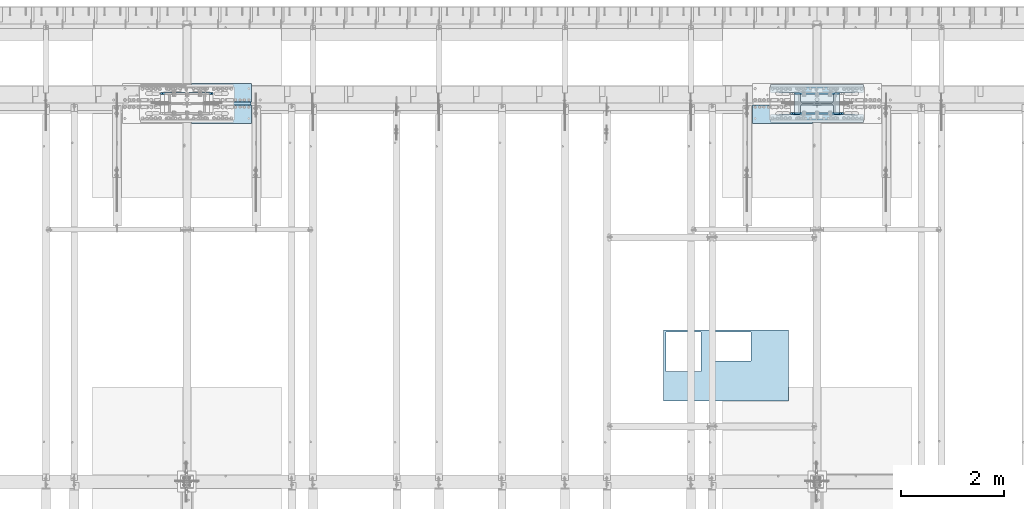
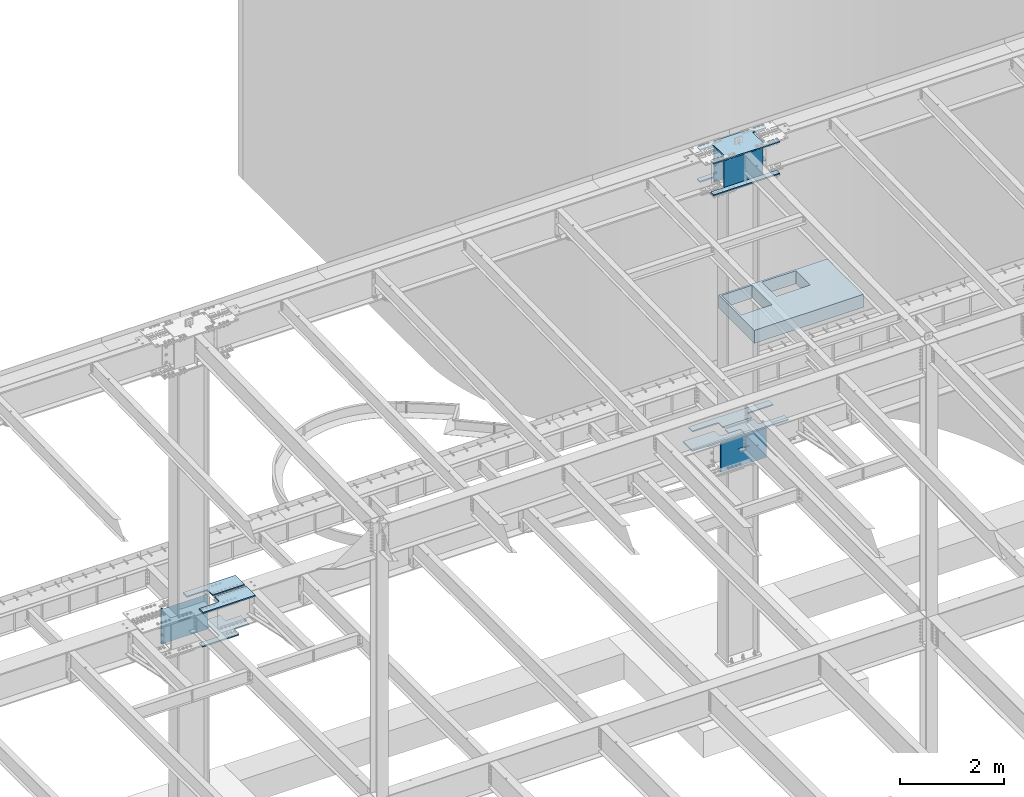
# One storey, part 1422 of 1763: 14 plates, 7 elements without a shape of their own.
"""IFC2X3 building model written with IfcOpenShell, lengths in millimetres."""

from ifc_helpers import new_model, si_unit, frame, origin_with_axes, place, context, subcontext, project, spatial, faceted_brep, material, type_object, element, aggregate, save


model = new_model("IFC2X3")

# Units and contexts
model_context = context("Model", 3, precision=1e-05, world=origin_with_axes())
body_context = subcontext(model_context, "Body", "Model", "MODEL_VIEW")
ifc_project = project(units=[si_unit("LENGTHUNIT", "METRE", prefix="MILLI"), si_unit("AREAUNIT", "SQUARE_METRE"), si_unit("VOLUMEUNIT", "CUBIC_METRE"), si_unit("MASSUNIT", "GRAM", prefix="KILO"), si_unit("TIMEUNIT", "SECOND"), si_unit("PLANEANGLEUNIT", "RADIAN"), si_unit("SOLIDANGLEUNIT", "STERADIAN"), si_unit("THERMODYNAMICTEMPERATUREUNIT", "DEGREE_CELSIUS"), si_unit("LUMINOUSINTENSITYUNIT", "LUMEN")], contexts=[model_context])

# Site, building, storey
site_placement = place(None, origin_with_axes())
site = spatial("IfcSite", under=ifc_project, at=site_placement, CompositionType="ELEMENT")
building_placement = place(site_placement, origin_with_axes())
building = spatial("IfcBuilding", under=site, at=building_placement, Name="Undefined", CompositionType="ELEMENT")
storey_placement = place(building_placement, origin_with_axes())
storey = spatial("IfcBuildingStorey", under=building, at=storey_placement, Name="Undefined", CompositionType="ELEMENT", Elevation=0.0)

# Assembly, plate
assembly_1_placement = place(storey_placement, origin_with_axes())
assembly_1 = element("IfcElementAssembly", 1, at=assembly_1_placement, inside=storey, Name="B-BOX", AssemblyPlace="NOTDEFINED", PredefinedType="RIGID_FRAME")
ifc_material_1 = material(Name="STEEL/A36")
plate_type_1 = type_object("IfcPlateType", PredefinedType="NOTDEFINED")
plate_1_placement = place(assembly_1_placement, frame((-52372.9740523809, 47740.7113892201, 11747.5), z_axis=(1.0, 0.0, 0.0), x_axis=(0.0, -1.0, 0.0)))
plate_1 = element("IfcPlate", 2, at=plate_1_placement, type_object=plate_type_1, material=ifc_material_1, Name="B-BOX", context=body_context, shape_type="Brep", body=[
    faceted_brep([(596.899999999994, -152.4, 1691.12592269852), (596.899999999994, 152.4, 1691.12592269852), (596.899999999994, 152.4, 939.803901214145), (596.899999999994, -152.4, 939.803901214145), (44.4499877929629, 152.4, 939.803901214145), (44.4499877929629, -152.4, 939.803901214145), (44.4499877929629, 152.4, 1695.45388175919), (44.4499877929629, -152.4, 1695.45388175919), (596.899999999994, 152.4, 1695.45388175919), (596.899999999994, -152.4, 1695.45388175919), (1377.94995117188, -152.4, 0.0), (0.0, -152.4, 0.0), (0.0, 152.4, 0.0), (1377.94995117188, 152.4, 0.0), (1377.94995117188, -152.4, 2422.52490234375), (1377.94995117188, 152.4, 2422.52490234375), (0.0, -152.4, 2422.52490234375), (0.0, 152.4, 2422.52490234375), (44.4499999999971, -152.4, 44.4499999999971), (44.4500244140654, -152.4, 723.903857421872), (800.091015625003, -152.4, 723.903857421872), (800.091015625003, -152.4, 44.4499999999971), (44.4499999999971, 152.4, 44.4499999999971), (44.4500244140654, 152.4, 723.903857421872), (800.091015625003, 152.4, 44.4499999999971), (800.091015625003, 152.4, 723.903857421872)], [[[0, 1, 2, 3]], [[3, 2, 4, 5]], [[5, 4, 6, 7]], [[7, 6, 8, 9]], [[9, 8, 1, 0]], [[10, 11, 12, 13]], [[14, 10, 13, 15]], [[16, 14, 15, 17]], [[11, 16, 17, 12]], [[10, 14, 16, 11], [3, 5, 7, 9, 0], [18, 19, 20, 21]], [[18, 22, 23, 19]], [[21, 24, 22, 18]], [[20, 25, 24, 21]], [[19, 23, 25, 20]], [[15, 13, 12, 17], [4, 2, 1, 8, 6], [22, 24, 25, 23]]]),
])
aggregate(assembly_1, [plate_1])

# Assembly, plates
assembly_2_placement = place(storey_placement, origin_with_axes())
assembly_2 = element("IfcElementAssembly", 3, at=assembly_2_placement, inside=storey, Name="COLUMN", AssemblyPlace="NOTDEFINED", PredefinedType="RIGID_FRAME")
ifc_material_2 = material(Name="STEEL/A572-50")
plate_type_2 = type_object("IfcPlateType", PredefinedType="NOTDEFINED")
plate_2_placement = place(assembly_2_placement, frame((-48505.4997736984, 52111.275, 5180.0125), z_axis=(-1.0, 0.0, 0.0), x_axis=(0.0, -1.0, 0.0)))
plate_2 = element("IfcPlate", 4, at=plate_2_placement, type_object=plate_type_2, material=ifc_material_2, Name="PLATE", context=body_context, shape_type="Brep", body=[
    faceted_brep([(174.62499427794, 14.2875000000004, 574.67504882811), (174.62499427794, -14.2875000000004, 574.67504882811), (38.0999984741429, -14.2875000000004, 574.675024414115), (38.0999984741429, 14.2875000000004, 574.67504882811), (184.345153314032, 14.2875000000004, 572.741588982935), (184.345153314032, -14.2875000000004, 572.741588982935), (192.58550625034, 14.2875000000004, 567.23556118198), (192.58550625034, -14.2875000000004, 567.23556118198), (198.091534051295, 14.2875000000004, 558.995208245673), (198.091534051295, -14.2875000000004, 558.995208245673), (200.02499389647, 14.2875000000004, 549.27504920958), (200.02499389647, -14.2875000000004, 549.27504920958), (200.02499389647, 14.2875000000004, 0.0), (200.02499389647, -14.2875000000004, 0.0), (358.774993896484, 14.2875000000004, 0.0), (358.774993896484, -14.2875000000004, 0.0), (358.774993896484, -14.2875000000004, 1793.875), (358.774993896484, 14.2875000000004, 1793.875), (200.024993896448, 14.2875000000004, 1793.875), (200.024993896448, -14.2875000000004, 1793.87502441408), (200.024993896448, 14.2875000000004, 1244.59997520449), (200.024993896448, -14.2875000000004, 1244.59997520449), (198.091534051273, 14.2875000000004, 1234.8798161684), (198.091534051273, -14.2875000000004, 1234.8798161684), (192.585506250318, 14.2875000000004, 1226.63946323209), (192.585506250318, -14.2875000000004, 1226.63946323209), (184.345153314011, 14.2875000000004, 1221.13343543113), (184.345153314011, -14.2875000000004, 1221.13343543113), (174.624994277918, 14.2875000000004, 1219.19997558596), (174.624994277918, -14.2875000000004, 1219.19997558596), (38.0999984740847, 14.2875000000067, 1219.19997558596), (38.0999984740847, -14.2875000000004, 1219.19997558593), (28.1663910320713, 14.2875000000067, 1209.26636814396), (0.0, -14.2875000000004, 1181.09997711187), (0.0, -14.2875000000004, 612.775022888178), (28.166391032064, 14.2875000000004, 584.608646085639)], [[[0, 1, 2, 3]], [[1, 0, 4, 5]], [[5, 4, 6, 7]], [[7, 6, 8, 9]], [[9, 8, 10, 11]], [[11, 10, 12, 13]], [[14, 15, 13, 12]], [[16, 15, 14, 17]], [[16, 17, 18, 19]], [[19, 18, 20, 21]], [[21, 20, 22, 23]], [[23, 22, 24, 25]], [[25, 24, 26, 27]], [[27, 26, 28, 29]], [[29, 28, 30, 31]], [[31, 30, 32, 33]], [[2, 1, 5, 7, 9, 11, 13, 15, 16, 19, 21, 23, 25, 27, 29, 31, 33, 34]], [[3, 2, 34, 35]], [[30, 28, 26, 24, 22, 20, 18, 17, 14, 12, 10, 8, 6, 4, 0, 3, 35, 32]], [[34, 33, 32, 35]]]),
])
plate_3_placement = place(assembly_2_placement, frame((-48505.4997736984, 52130.325, 5180.0125), z_axis=(-1.0, 0.0, 0.0), x_axis=(0.0, 1.0, 0.0)))
plate_3 = element("IfcPlate", 5, at=plate_3_placement, type_object=plate_type_2, material=ifc_material_2, Name="PLATE", context=body_context, shape_type="Brep", body=[
    faceted_brep([(174.62499427794, 14.2875000000004, 574.67504882811), (174.62499427794, -14.2875000000004, 574.67504882811), (38.0999984741429, -14.2875000000004, 574.675024414115), (38.0999984741429, 14.2875000000004, 574.67504882811), (184.345153314032, 14.2875000000004, 572.741588982935), (184.345153314032, -14.2875000000004, 572.741588982935), (192.58550625034, 14.2875000000004, 567.23556118198), (192.58550625034, -14.2875000000004, 567.23556118198), (198.091534051295, 14.2875000000004, 558.995208245673), (198.091534051295, -14.2875000000004, 558.995208245673), (200.02499389647, 14.2875000000004, 549.27504920958), (200.02499389647, -14.2875000000004, 549.27504920958), (200.02499389647, 14.2875000000004, 0.0), (200.02499389647, -14.2875000000004, 0.0), (358.774993896484, 14.2875000000004, 0.0), (358.774993896484, -14.2875000000004, 0.0), (358.774993896484, -14.2875000000004, 1793.875), (358.774993896484, 14.2875000000004, 1793.875), (200.024993896448, 14.2875000000004, 1793.875), (200.024993896448, -14.2875000000004, 1793.87502441408), (200.024993896448, 14.2875000000004, 1244.59997520449), (200.024993896448, -14.2875000000004, 1244.59997520449), (198.091534051273, 14.2875000000004, 1234.8798161684), (198.091534051273, -14.2875000000004, 1234.8798161684), (192.585506250318, 14.2875000000004, 1226.63946323209), (192.585506250318, -14.2875000000004, 1226.63946323209), (184.345153314011, 14.2875000000004, 1221.13343543113), (184.345153314011, -14.2875000000004, 1221.13343543113), (174.624994277918, 14.2875000000004, 1219.19997558596), (174.624994277918, -14.2875000000004, 1219.19997558596), (38.0999984740847, 14.2875000000067, 1219.19997558596), (38.0999984740847, -14.2875000000004, 1219.19997558593), (28.5750000000116, -14.2875000000067, 1209.67497711188), (28.5750000000044, -14.2875000000004, 584.200022888232), (0.0, 14.2875000000004, 612.775022888178), (0.0, 14.2875000000004, 1181.09997711187)], [[[0, 1, 2, 3]], [[1, 0, 4, 5]], [[5, 4, 6, 7]], [[7, 6, 8, 9]], [[9, 8, 10, 11]], [[11, 10, 12, 13]], [[14, 15, 13, 12]], [[16, 15, 14, 17]], [[16, 17, 18, 19]], [[19, 18, 20, 21]], [[21, 20, 22, 23]], [[23, 22, 24, 25]], [[25, 24, 26, 27]], [[27, 26, 28, 29]], [[29, 28, 30, 31]], [[2, 1, 5, 7, 9, 11, 13, 15, 16, 19, 21, 23, 25, 27, 29, 31, 32, 33]], [[3, 2, 33, 34]], [[30, 28, 26, 24, 22, 20, 18, 17, 14, 12, 10, 8, 6, 4, 0, 3, 34, 35]], [[31, 30, 35, 32]], [[34, 33, 32, 35]]]),
])

# Assembly, plate
assembly_3_placement = place(storey_placement, origin_with_axes())
assembly_3 = element("IfcElementAssembly", 6, at=assembly_3_placement, inside=storey, Name="TOP PLATE", AssemblyPlace="NOTDEFINED", PredefinedType="RIGID_FRAME")
plate_4_placement = place(assembly_3_placement, frame((-49950.1247736984, 52092.225, 5208.5875), z_axis=(0.0, -1.0, 0.0), x_axis=(-1.0, 0.0, 0.0)))
plate_4 = element("IfcPlate", 7, at=plate_4_placement, type_object=plate_type_2, material=ifc_material_2, Name="TOP PLATE", context=body_context, shape_type="Brep", body=[
    faceted_brep([(0.0, -14.2875000000058, 0.0), (0.0, -14.2875000000004, 161.924999237061), (0.0, 14.2875000000004, 161.924999237061), (0.0, 14.2875000000058, 0.0), (-3.38355483794294, -14.2875000000004, 178.935278097655), (-3.38355483794294, 14.2875000000004, 178.935278097655), (-13.0191037997138, -14.2875000000004, 193.355896200279), (-13.0191037997138, 14.2875000000004, 193.355896200279), (-27.4397219023522, -14.2875000000004, 202.99144516205), (-27.4397219023522, 14.2875000000004, 202.99144516205), (-44.4500007629395, -14.2875000000004, 206.375), (-44.4500007629395, 14.2875000000004, 206.375), (-457.200012207031, -14.2875000000004, 206.375), (-457.200012207031, 14.2875000000004, 206.375), (-457.200012207031, -14.2875000000004, 358.774993896484), (-457.200012207031, 14.2875000000004, 358.774993896484), (701.674987792969, -14.2875000000004, 358.774993896484), (701.674987792969, 14.2875000000004, 358.774993896484), (701.674987792969, -14.2875000000004, 0.0), (701.674987792969, 14.2875000000004, 0.0)], [[[0, 1, 2, 3]], [[1, 4, 5, 2]], [[4, 6, 7, 5]], [[6, 8, 9, 7]], [[8, 10, 11, 9]], [[10, 12, 13, 11]], [[12, 14, 15, 13]], [[14, 16, 17, 15]], [[16, 18, 19, 17]], [[18, 0, 3, 19]], [[5, 7, 9, 11, 13, 15, 17, 19, 3, 2]], [[18, 16, 14, 12, 10, 8, 6, 4, 1, 0]]]),
])
aggregate(assembly_3, [plate_4])

assembly_4_placement = place(storey_placement, origin_with_axes())
assembly_4 = element("IfcElementAssembly", 8, at=assembly_4_placement, inside=storey, Name="TOP PLATE", AssemblyPlace="NOTDEFINED", PredefinedType="RIGID_FRAME")
plate_5_placement = place(assembly_4_placement, frame((-60345.0747736983, 52092.225, 5208.5875), z_axis=(0.0, -1.0, 0.0), x_axis=(-1.0, 0.0, 0.0)))
plate_5 = element("IfcPlate", 9, at=plate_5_placement, type_object=plate_type_2, material=ifc_material_2, Name="TOP PLATE", context=body_context, shape_type="Brep", body=[
    faceted_brep([(0.0, -14.2875000000058, 0.0), (0.0, -14.2875000000004, 358.774993896484), (0.0, 14.2875000000004, 358.774993896484), (0.0, 14.2875000000058, 0.0), (1158.875, -14.2875000000004, 358.774993896484), (1158.875, 14.2875000000004, 358.774993896484), (1158.875, -14.2875000000004, 206.375), (1158.875, 14.2875000000004, 206.375), (746.124988555908, -14.2875000000004, 206.375), (746.124988555908, 14.2875000000004, 206.375), (729.114709695321, -14.2875000000004, 202.99144516205), (729.114709695321, 14.2875000000004, 202.99144516205), (714.694091592683, -14.2875000000004, 193.355896200279), (714.694091592683, 14.2875000000004, 193.355896200279), (705.058542630912, -14.2875000000004, 178.935278097655), (705.058542630912, 14.2875000000004, 178.935278097655), (701.674987792969, -14.2875000000004, 161.924999237061), (701.674987792969, 14.2875000000004, 161.924999237061), (701.674987792969, -14.2875000000004, 0.0), (701.674987792969, 14.2875000000004, 0.0)], [[[0, 1, 2, 3]], [[1, 4, 5, 2]], [[4, 6, 7, 5]], [[6, 8, 9, 7]], [[8, 10, 11, 9]], [[10, 12, 13, 11]], [[12, 14, 15, 13]], [[14, 16, 17, 15]], [[16, 18, 19, 17]], [[18, 0, 3, 19]], [[5, 7, 9, 11, 13, 15, 17, 19, 3, 2]], [[18, 16, 14, 12, 10, 8, 6, 4, 1, 0]]]),
])
aggregate(assembly_4, [plate_5])

assembly_5_placement = place(storey_placement, origin_with_axes())
assembly_5 = element("IfcElementAssembly", 10, at=assembly_5_placement, inside=storey, Name="TOP PLATE", AssemblyPlace="NOTDEFINED", PredefinedType="RIGID_FRAME")
plate_6_placement = place(assembly_5_placement, frame((-61046.7497736983, 52149.375, 5208.5875), z_axis=(0.0, 1.0, 0.0), x_axis=(1.0, 0.0, 0.0)))
plate_6 = element("IfcPlate", 11, at=plate_6_placement, type_object=plate_type_2, material=ifc_material_2, Name="TOP PLATE", context=body_context, shape_type="Brep", body=[
    faceted_brep([(0.0, -14.2875000000058, 0.0), (0.0, -14.2875000000004, 161.924999237061), (0.0, 14.2875000000004, 161.924999237061), (0.0, 14.2875000000058, 0.0), (-3.38355483794294, -14.2875000000004, 178.935278097655), (-3.38355483794294, 14.2875000000004, 178.935278097655), (-13.0191037997138, -14.2875000000004, 193.355896200279), (-13.0191037997138, 14.2875000000004, 193.355896200279), (-27.4397219023522, -14.2875000000004, 202.99144516205), (-27.4397219023522, 14.2875000000004, 202.99144516205), (-44.4500007629395, -14.2875000000004, 206.375), (-44.4500007629395, 14.2875000000004, 206.375), (-457.200012207031, -14.2875000000004, 206.375), (-457.200012207031, 14.2875000000004, 206.375), (-457.200012207031, -14.2875000000004, 358.774993896484), (-457.200012207031, 14.2875000000004, 358.774993896484), (701.674987792969, -14.2875000000004, 358.774993896484), (701.674987792969, 14.2875000000004, 358.774993896484), (701.674987792969, -14.2875000000004, 0.0), (701.674987792969, 14.2875000000004, 0.0)], [[[0, 1, 2, 3]], [[1, 4, 5, 2]], [[4, 6, 7, 5]], [[6, 8, 9, 7]], [[8, 10, 11, 9]], [[10, 12, 13, 11]], [[12, 14, 15, 13]], [[14, 16, 17, 15]], [[16, 18, 19, 17]], [[18, 0, 3, 19]], [[5, 7, 9, 11, 13, 15, 17, 19, 3, 2]], [[18, 16, 14, 12, 10, 8, 6, 4, 1, 0]]]),
])
aggregate(assembly_5, [plate_6])

# Plate
plate_type_3 = type_object("IfcPlateType", PredefinedType="NOTDEFINED")
plate_7_placement = place(assembly_2_placement, frame((-50137.4497736983, 52441.4750002128, 11733.2124917654), z_axis=(1.0, 0.0, 0.0), x_axis=(0.0, -1.0, 0.0)))
plate_7 = element("IfcPlate", 12, at=plate_7_placement, type_object=plate_type_3, material=ifc_material_2, Name="PLATE", context=body_context, shape_type="Brep", body=[
    faceted_brep([(117.474998474121, -14.2875000000004, 1470.02502441406), (117.475000194951, -14.2875000000004, 1193.7999996006), (117.475000166465, 14.2875000000004, 1193.79999957211), (117.474998474121, 14.2875000000004, 1470.02502441406), (119.40846004527, -14.2875000000004, 1184.07984057001), (119.408460016784, 14.2875000000004, 1184.07984054153), (124.914487847418, -14.2875000000004, 1175.83948763979), (124.914487818933, 14.2875000000004, 1175.8394876113), (133.154840781528, -14.2875000000004, 1170.33345984345), (133.154840753043, 14.2875000000004, 1170.33345981497), (142.874999813481, -14.2875000000004, 1168.39999999999), (142.874999784995, 14.2875000000004, 1168.3999999715), (498.474994490825, -14.2875000000004, 1168.39999999997), (498.47499446234, 14.2875000000004, 1168.39999997149), (508.195153526918, -14.2875000000004, 1170.33345984515), (508.195153498433, 14.2875000000004, 1170.33345981667), (516.435506463225, -14.2875000000004, 1175.83948764611), (516.43550643474, 14.2875000000004, 1175.83948761762), (521.941534264181, -14.2875000000004, 1184.07984058242), (521.941534235695, 14.2875000000004, 1184.07984055393), (523.874994109356, -14.2875000000004, 1193.7999996185), (523.874994080878, 14.2875000000004, 1193.79999959002), (523.874994109356, -14.2875000000004, 1470.02503051757), (523.874994080878, 14.2875000000004, 1470.02502441406), (0.0, -14.2875000000058, 0.0), (-2.91038304567337e-11, -14.2875000000004, 1470.02502441406), (-2.91038304567337e-11, 14.2875000000004, 1470.02502441406), (0.0, 14.2875000000058, 0.0), (117.474975585938, -14.2875000000004, 0.0), (117.474975585938, 14.2875000000004, 0.0), (117.475000167673, 14.2875000000004, 276.224976013829), (117.475000196158, -14.2875000000004, 276.224975985344), (119.408460017992, 14.2875000000004, 285.945135044414), (119.408460046478, -14.2875000000004, 285.945135015929), (124.91448782014, 14.2875000000004, 294.185487974639), (124.914487848626, -14.2875000000004, 294.185487946153), (133.154840754258, 14.2875000000004, 299.691515770974), (133.154840782736, -14.2875000000004, 299.691515742488), (142.874999786203, 14.2875000000004, 301.624975614432), (142.874999814689, -14.2875000000004, 301.624975585954), (498.474994463555, 14.2875000000004, 301.624975614432), (498.474994492033, -14.2875000000004, 301.624975585954), (508.195153499641, 14.2875000000004, 299.691515769257), (508.195153528126, -14.2875000000004, 299.691515740778), (516.435506435948, 14.2875000000004, 294.185487968301), (516.435506464433, -14.2875000000004, 294.185487939816), (521.941534236903, 14.2875000000004, 285.945135031994), (521.941534265388, -14.2875000000004, 285.945135003509), (523.874994082085, 14.2875000000004, 276.224975995901), (523.874994110563, -14.2875000000004, 276.224975967423), (523.874994082085, 14.2875000000004, 1.45519152283669e-11), (523.874994110563, -14.2875000000004, 1.45519152283669e-11), (641.349975585938, 14.2875000000004, 1.45519152283669e-11), (641.349975585938, -14.2875000000004, 1.45519152283669e-11), (641.349975585938, -14.2875000000004, 1470.02502441406), (641.349975585938, 14.2875000000004, 1470.02502441406)], [[[0, 1, 2, 3]], [[4, 5, 2, 1]], [[6, 7, 5, 4]], [[8, 9, 7, 6]], [[10, 11, 9, 8]], [[12, 13, 11, 10]], [[14, 15, 13, 12]], [[16, 17, 15, 14]], [[18, 19, 17, 16]], [[20, 21, 19, 18]], [[22, 23, 21, 20]], [[24, 25, 26, 27]], [[28, 24, 27, 29]], [[28, 29, 30, 31]], [[31, 30, 32, 33]], [[33, 32, 34, 35]], [[35, 34, 36, 37]], [[37, 36, 38, 39]], [[39, 38, 40, 41]], [[41, 40, 42, 43]], [[43, 42, 44, 45]], [[45, 44, 46, 47]], [[47, 46, 48, 49]], [[49, 48, 50, 51]], [[52, 53, 51, 50]], [[54, 53, 52, 55]], [[18, 16, 14, 12, 10, 8, 6, 4, 1, 0, 25, 24, 28, 31, 33, 35, 37, 39, 41, 43, 45, 47, 49, 51, 53, 54, 22, 20]], [[25, 0, 3, 26]], [[55, 52, 50, 48, 46, 44, 42, 40, 38, 36, 34, 32, 30, 29, 27, 26, 3, 2, 5, 7, 9, 11, 13, 15, 17, 19, 21, 23]], [[54, 55, 23, 22]]]),
])

plate_type_4 = type_object("IfcPlateType", PredefinedType="NOTDEFINED")
plate_8_placement = place(assembly_2_placement, frame((-50137.4497736984, 51917.6000002128, 10983.9124917654), z_axis=(1.0, 0.0, 0.0), x_axis=(0.0, -1.0, 0.0)))
plate_8 = element("IfcPlate", 13, at=plate_8_placement, type_object=plate_type_4, material=ifc_material_1, Name="PLATE", context=body_context, shape_type="Brep", body=[
    faceted_brep([(0.0, -14.2875000000058, 0.0), (-2.91038304567337e-11, -14.2875000000004, 1470.02502441406), (-2.91038304567337e-11, 14.2875000000004, 1470.02502441406), (0.0, 14.2875000000058, 0.0), (117.474998474121, -14.2875000000004, 1470.02502441406), (117.474998474121, 14.2875000000004, 1470.02502441406), (117.474975585938, -14.2875000000004, 0.0), (117.474975585938, 14.2875000000004, 0.0)], [[[0, 1, 2, 3]], [[1, 4, 5, 2]], [[4, 6, 7, 5]], [[6, 0, 3, 7]], [[5, 7, 3, 2]], [[6, 4, 1, 0]]]),
])

plate_9_placement = place(assembly_2_placement, frame((-50137.4497736983, 52324.0000017387, 10983.9124917654), z_axis=(0.0, 1.0, 0.0), x_axis=(1.0, 0.0, 0.0)))
plate_9 = element("IfcPlate", 14, at=plate_9_placement, type_object=plate_type_4, material=ifc_material_1, Name="PLATE", context=body_context, shape_type="Brep", body=[
    faceted_brep([(0.0, -14.2875000000058, 0.0), (0.0, -14.2875000000004, 117.474998474121), (0.0, 14.2875000000004, 117.474998474121), (0.0, 14.2875000000058, 0.0), (1470.02502441406, -14.2875000000004, 117.474998474121), (1470.02502441406, 14.2875000000004, 117.474998474121), (1470.02502441406, -14.2875000000004, 7.27595761418343e-12), (1470.02502441406, 14.2875000000004, 7.27595761418343e-12)], [[[0, 1, 2, 3]], [[1, 4, 5, 2]], [[4, 6, 7, 5]], [[6, 0, 3, 7]], [[5, 7, 3, 2]], [[6, 4, 1, 0]]]),
])

plate_type_5 = type_object("IfcPlateType", PredefinedType="NOTDEFINED")
plate_10_placement = place(assembly_2_placement, frame((-48969.0497736697, 52311.3, 11718.9249917654), z_axis=(0.0, 0.0, -1.0), x_axis=(-1.0, 0.0, 0.0)))
plate_10 = element("IfcPlate", 15, at=plate_10_placement, type_object=plate_type_5, material=ifc_material_2, Name="COVER PLATE", context=body_context, shape_type="Brep", body=[
    faceted_brep([(0.0, -12.6999999999971, -1.81898940354586e-12), (2.85799615085125e-08, -12.6999999999971, 825.5), (2.85799615085125e-08, 12.6999999999971, 825.5), (0.0, 12.6999999999971, -1.81898940354586e-12), (866.775024414062, -12.6999999999971, 825.5), (866.775024414062, 12.6999999999971, 825.5), (866.775024414062, -12.6999999999971, 0.0), (866.775024414062, 12.6999999999971, 0.0)], [[[0, 1, 2, 3]], [[1, 4, 5, 2]], [[4, 6, 7, 5]], [[6, 0, 3, 7]], [[5, 7, 3, 2]], [[6, 4, 1, 0]]]),
])

plate_11_placement = place(assembly_2_placement, frame((-48969.0497736697, 51930.3, 11718.9249917654), z_axis=(0.0, 0.0, -1.0), x_axis=(-1.0, 0.0, 0.0)))
plate_11 = element("IfcPlate", 16, at=plate_11_placement, type_object=plate_type_5, material=ifc_material_2, Name="COVER PLATE", context=body_context, shape_type="Brep", body=[
    faceted_brep([(0.0, -12.6999999999971, -1.81898940354586e-12), (2.85799615085125e-08, -12.6999999999971, 825.5), (2.85799615085125e-08, 12.6999999999971, 825.5), (0.0, 12.6999999999971, -1.81898940354586e-12), (866.775024414062, -12.6999999999971, 825.5), (866.775024414062, 12.6999999999971, 825.5), (866.775024414062, -12.6999999999971, 0.0), (866.775024414062, 12.6999999999971, 0.0)], [[[0, 1, 2, 3]], [[1, 4, 5, 2]], [[4, 6, 7, 5]], [[6, 0, 3, 7]], [[5, 7, 3, 2]], [[6, 4, 1, 0]]]),
])

# Assembly, plate
assembly_6_placement = place(storey_placement, origin_with_axes())
assembly_6 = element("IfcElementAssembly", 17, at=assembly_6_placement, inside=storey, Name="PLATE", AssemblyPlace="NOTDEFINED", PredefinedType="RIGID_FRAME")
plate_type_6 = type_object("IfcPlateType", PredefinedType="NOTDEFINED")
plate_12_placement = place(assembly_6_placement, frame((-61503.9497736983, 51752.5, 4405.3125), z_axis=(0.0, 1.0, 0.0), x_axis=(1.0, 0.0, 0.0)))
plate_12 = element("IfcPlate", 18, at=plate_12_placement, type_object=plate_type_6, material=ifc_material_2, Name="PLATE", context=body_context, shape_type="Brep", body=[
    faceted_brep([(0.0, -14.2875000000058, 0.0), (0.0, -14.2875000000004, 133.350006103516), (0.0, 14.2875000000004, 133.350006103516), (0.0, 14.2875000000058, 0.0), (417.512512207031, -14.2875000000004, 133.350006103516), (417.512512207031, 14.2875000000004, 133.350006103516), (429.776624171282, -14.2875000000004, 135.292450613051), (429.776624171282, 14.2875000000004, 135.292450613051), (440.840239407393, -14.2875000000004, 140.929644139258), (440.840239407393, 14.2875000000004, 140.929644139258), (449.620374171282, -14.2875000000004, 149.709778903161), (449.620374171282, 14.2875000000004, 149.709778903161), (455.257567697496, -14.2875000000004, 160.773394139258), (455.257567697496, 14.2875000000004, 160.773394139258), (457.200012207031, -14.2875000000004, 173.037506103516), (457.200012207031, 14.2875000000004, 173.037506103516), (457.200012207031, -14.2875000000004, 563.5625), (457.200012207031, 14.2875000000004, 563.5625), (455.257567697496, -14.2875000000004, 575.826611964258), (455.257567697496, 14.2875000000004, 575.826611964258), (449.620374171282, -14.2875000000004, 586.890227200354), (449.620374171282, 14.2875000000004, 586.890227200354), (440.840239407393, -14.2875000000004, 595.670361964258), (440.840239407393, 14.2875000000004, 595.670361964258), (429.776624171282, -14.2875000000004, 601.307555490464), (429.776624171282, 14.2875000000004, 601.307555490464), (417.512512207031, -14.2875000000004, 603.25), (417.512512207031, 14.2875000000004, 603.25), (0.0, -14.2875000000004, 603.25), (0.0, 14.2875000000004, 603.25), (0.0, -14.2875000000004, 736.599975585938), (0.0, 14.2875000000004, 736.599975585938), (806.450012207031, -14.2875000000004, 736.599975585938), (806.450012207031, 14.2875000000004, 736.599975585938), (806.450012207031, -14.2875000000004, 563.5625), (806.450012207031, 14.2875000000004, 563.5625), (808.392456716567, -14.2875000000004, 551.298388035742), (808.392456716567, 14.2875000000004, 551.298388035742), (814.029650242781, -14.2875000000004, 540.234772799646), (814.029650242781, 14.2875000000004, 540.234772799646), (822.80978500667, -14.2875000000004, 531.454638035742), (822.80978500667, 14.2875000000004, 531.454638035742), (833.873400242781, -14.2875000000004, 525.817444509536), (833.873400242781, 14.2875000000004, 525.817444509536), (846.137512207031, -14.2875000000004, 523.875), (846.137512207031, 14.2875000000004, 523.875), (1149.34997558594, -14.2875000000004, 523.875), (1149.34997558594, 14.2875000000004, 523.875), (1149.34997558594, -14.2875000000004, 212.725006103516), (1149.34997558594, 14.2875000000004, 212.725006103516), (846.137512207031, -14.2875000000004, 212.725006103516), (846.137512207031, 14.2875000000004, 212.725006103516), (833.873400242781, -14.2875000000004, 210.78256159398), (833.873400242781, 14.2875000000004, 210.78256159398), (822.80978500667, -14.2875000000004, 205.145368067773), (822.80978500667, 14.2875000000004, 205.145368067773), (814.029650242781, -14.2875000000004, 196.36523330387), (814.029650242781, 14.2875000000004, 196.36523330387), (808.392456716567, -14.2875000000004, 185.301618067773), (808.392456716567, 14.2875000000004, 185.301618067773), (806.450012207031, -14.2875000000004, 173.037506103516), (806.450012207031, 14.2875000000004, 173.037506103516), (806.450012207031, -14.2875000000004, 0.0), (806.450012207031, 14.2875000000004, 0.0)], [[[0, 1, 2, 3]], [[1, 4, 5, 2]], [[4, 6, 7, 5]], [[6, 8, 9, 7]], [[8, 10, 11, 9]], [[10, 12, 13, 11]], [[12, 14, 15, 13]], [[14, 16, 17, 15]], [[16, 18, 19, 17]], [[18, 20, 21, 19]], [[20, 22, 23, 21]], [[22, 24, 25, 23]], [[24, 26, 27, 25]], [[26, 28, 29, 27]], [[28, 30, 31, 29]], [[30, 32, 33, 31]], [[32, 34, 35, 33]], [[34, 36, 37, 35]], [[36, 38, 39, 37]], [[38, 40, 41, 39]], [[40, 42, 43, 41]], [[42, 44, 45, 43]], [[44, 46, 47, 45]], [[46, 48, 49, 47]], [[48, 50, 51, 49]], [[50, 52, 53, 51]], [[52, 54, 55, 53]], [[54, 56, 57, 55]], [[56, 58, 59, 57]], [[58, 60, 61, 59]], [[60, 62, 63, 61]], [[62, 0, 3, 63]], [[5, 7, 9, 11, 13, 15, 17, 19, 21, 23, 25, 27, 29, 31, 33, 35, 37, 39, 41, 43, 45, 47, 49, 51, 53, 55, 57, 59, 61, 63, 3, 2]], [[62, 60, 58, 56, 54, 52, 50, 48, 46, 44, 42, 40, 38, 36, 34, 32, 30, 28, 26, 24, 22, 20, 18, 16, 14, 12, 10, 8, 6, 4, 1, 0]]]),
])
aggregate(assembly_6, [plate_12])

# Plate
plate_type_7 = type_object("IfcPlateType", PredefinedType="NOTDEFINED")
plate_13_placement = place(assembly_2_placement, frame((-49912.0247736984, 51927.125, 5165.725), z_axis=(0.0, 0.0, -1.0), x_axis=(1.0, 0.0, 0.0)))
plate_13 = element("IfcPlate", 19, at=plate_13_placement, type_object=plate_type_7, material=ifc_material_2, Name="COVER PLATE", context=body_context, shape_type="Brep", body=[
    faceted_brep([(984.249999237072, 15.8750000000218, 31.7499999999918), (984.249999237072, -15.875, 0.0), (796.9250236511, -15.875, 0.0), (796.9250236511, 15.8750000000073, 31.7499999999991), (984.249999237072, 15.875, 0.0), (34.9249992370751, 15.8750000000218, 31.7499999999918), (34.9249992370751, -15.875, 0.0), (34.9249992370751, 15.875, 0.0), (222.250023651097, 15.8750000000218, 31.7499999999918), (222.250023651097, -15.875, 0.0), (0.0, -15.875, 0.0), (0.0, 15.875, 0.0), (0.0, -15.875, 822.324951171875), (0.0, 15.875, 822.324951171875), (1019.17498779297, -15.875, 822.324951171875), (1019.17498779297, 15.875, 822.324951171875), (1019.17498779297, -15.875, 0.0), (1019.17498779297, 15.875, 0.0), (631.745205739557, 15.875, 423.782722524225), (628.140051213893, 15.875, 426.191609764667), (623.88748149875, 15.875, 427.037498474155), (395.287500190767, 15.875, 427.037498474155), (391.034930475624, 15.875, 426.191609764667), (387.42977594996, 15.875, 423.782722524225), (385.020888709521, 15.875, 420.177567998568), (384.175000000032, 15.875, 415.925000190768), (385.020888709521, 15.875, 411.67243047562), (387.42977594996, 15.875, 408.067275949962), (391.034930475624, 15.875, 405.65838870952), (395.287500190767, 15.875, 404.812500000033), (623.88748149875, 15.875, 404.812500000009), (628.140051213893, 15.875, 405.658388709496), (631.745205739557, 15.875, 408.067275949938), (634.154092979996, 15.875, 411.672430475595), (634.999981689485, 15.875, 415.92499828342), (634.154092979996, 15.875, 420.177567998568), (634.154092979996, -15.875, 420.177567998568), (634.999981689485, -15.875, 415.92499828342), (631.745205739557, -15.875, 423.782722524225), (628.140051213893, -15.875, 426.191609764667), (623.88748149875, -15.875, 427.037498474155), (395.287500190767, -15.875, 427.037498474155), (391.034930475624, -15.875, 426.191609764667), (387.42977594996, -15.875, 423.782722524225), (385.020888709521, -15.875, 420.177567998568), (384.175000000032, -15.875, 415.925000190768), (385.020888709521, -15.875, 411.67243047562), (387.42977594996, -15.875, 408.067275949962), (391.034930475624, -15.875, 405.65838870952), (395.287500190767, -15.875, 404.812500000033), (623.88748149875, -15.875, 404.812500000009), (628.140051213893, -15.875, 405.658388709496), (631.745205739557, -15.875, 408.067275949938), (634.154092979996, -15.875, 411.672430475595)], [[[0, 1, 2, 3]], [[4, 1, 0]], [[5, 6, 7]], [[8, 9, 6, 5]], [[10, 11, 7, 6]], [[10, 12, 13, 11]], [[12, 14, 15, 13]], [[14, 16, 17, 15]], [[17, 16, 1, 4]], [[8, 5, 7, 11, 13, 15, 17, 4, 0, 3], [18, 19, 20, 21, 22, 23, 24, 25, 26, 27, 28, 29, 30, 31, 32, 33, 34, 35]], [[36, 35, 34, 37]], [[38, 18, 35, 36]], [[39, 19, 18, 38]], [[40, 20, 19, 39]], [[41, 21, 20, 40]], [[42, 22, 21, 41]], [[43, 23, 22, 42]], [[44, 24, 23, 43]], [[45, 25, 24, 44]], [[46, 26, 25, 45]], [[47, 27, 26, 46]], [[48, 28, 27, 47]], [[49, 29, 28, 48]], [[50, 30, 29, 49]], [[51, 31, 30, 50]], [[52, 32, 31, 51]], [[53, 33, 32, 52]], [[37, 34, 33, 53]], [[16, 14, 12, 10, 6, 9, 2, 1], [52, 51, 50, 49, 48, 47, 46, 45, 44, 43, 42, 41, 40, 39, 38, 36, 37, 53]], [[3, 2, 9, 8]]]),
])

aggregate(assembly_2, [plate_2, plate_3, plate_8, plate_7, plate_10, plate_11, plate_9, plate_13])

# Assembly, plate
assembly_7_placement = place(storey_placement, origin_with_axes())
assembly_7 = element("IfcElementAssembly", 20, at=assembly_7_placement, inside=storey, Name="COLUMN", AssemblyPlace="NOTDEFINED", PredefinedType="RIGID_FRAME")
plate_14_placement = place(assembly_7_placement, frame((-62104.0247736984, 52314.475, 5165.725), z_axis=(0.0, 0.0, -1.0), x_axis=(1.0, 0.0, 0.0)))
plate_14 = element("IfcPlate", 21, at=plate_14_placement, type_object=plate_type_7, material=ifc_material_2, Name="COVER PLATE", context=body_context, shape_type="Brep", body=[
    faceted_brep([(984.249999237072, -15.8749999999927, 31.7500000000036), (984.249999237072, 15.875, 0.0), (984.249999237072, -15.875, 0.0), (796.925023651071, -15.8750000000218, 31.7500000000109), (796.925023651071, 15.875, 0.0), (34.9249992370751, -15.875, 0.0), (34.9249992370751, 15.875, 0.0), (34.9249992370605, -15.8749999999927, 31.7500000000036), (222.250023651082, -15.8749999999927, 31.7500000000036), (222.250023651082, 15.875, 0.0), (0.0, -15.875, 0.0), (0.0, 15.875, 0.0), (0.0, -15.875, 822.324951171875), (0.0, 15.875, 822.324951171875), (1019.17498779297, -15.875, 822.324951171875), (1019.17498779297, 15.875, 822.324951171875), (1019.17498779297, -15.875, 0.0), (1019.17498779297, 15.875, 0.0), (631.745205739557, 15.875, 423.782722524225), (628.140051213893, 15.875, 426.191609764667), (623.88748149875, 15.875, 427.037498474155), (395.287500190767, 15.875, 427.037498474155), (391.034930475624, 15.875, 426.191609764667), (387.42977594996, 15.875, 423.782722524225), (385.020888709521, 15.875, 420.177567998568), (384.175000000032, 15.875, 415.925000190768), (385.020888709521, 15.875, 411.67243047562), (387.42977594996, 15.875, 408.067275949962), (391.034930475624, 15.875, 405.65838870952), (395.287500190767, 15.875, 404.812500000033), (623.88748149875, 15.875, 404.812500000009), (628.140051213893, 15.875, 405.658388709496), (631.745205739557, 15.875, 408.067275949938), (634.154092979996, 15.875, 411.672430475595), (634.999981689485, 15.875, 415.92499828342), (634.154092979996, 15.875, 420.177567998568), (634.154092979996, -15.875, 420.177567998568), (634.999981689485, -15.875, 415.92499828342), (631.745205739557, -15.875, 423.782722524225), (628.140051213893, -15.875, 426.191609764667), (623.88748149875, -15.875, 427.037498474155), (395.287500190767, -15.875, 427.037498474155), (391.034930475624, -15.875, 426.191609764667), (387.42977594996, -15.875, 423.782722524225), (385.020888709521, -15.875, 420.177567998568), (384.175000000032, -15.875, 415.925000190768), (385.020888709521, -15.875, 411.67243047562), (387.42977594996, -15.875, 408.067275949962), (391.034930475624, -15.875, 405.65838870952), (395.287500190767, -15.875, 404.812500000033), (623.88748149875, -15.875, 404.812500000009), (628.140051213893, -15.875, 405.658388709496), (631.745205739557, -15.875, 408.067275949938), (634.154092979996, -15.875, 411.672430475595)], [[[0, 1, 2]], [[3, 4, 1, 0]], [[5, 6, 7]], [[8, 7, 6, 9]], [[8, 9, 4, 3]], [[10, 11, 6, 5]], [[10, 12, 13, 11]], [[12, 14, 15, 13]], [[14, 16, 17, 15]], [[17, 16, 2, 1]], [[9, 6, 11, 13, 15, 17, 1, 4], [18, 19, 20, 21, 22, 23, 24, 25, 26, 27, 28, 29, 30, 31, 32, 33, 34, 35]], [[36, 35, 34, 37]], [[38, 18, 35, 36]], [[39, 19, 18, 38]], [[40, 20, 19, 39]], [[41, 21, 20, 40]], [[42, 22, 21, 41]], [[43, 23, 22, 42]], [[44, 24, 23, 43]], [[45, 25, 24, 44]], [[46, 26, 25, 45]], [[47, 27, 26, 46]], [[48, 28, 27, 47]], [[49, 29, 28, 48]], [[50, 30, 29, 49]], [[51, 31, 30, 50]], [[52, 32, 31, 51]], [[53, 33, 32, 52]], [[37, 34, 33, 53]], [[16, 14, 12, 10, 5, 7, 8, 3, 0, 2], [52, 51, 50, 49, 48, 47, 46, 45, 44, 43, 42, 41, 40, 39, 38, 36, 37, 53]]]),
])
aggregate(assembly_7, [plate_14])

save(model, "model.ifc")
